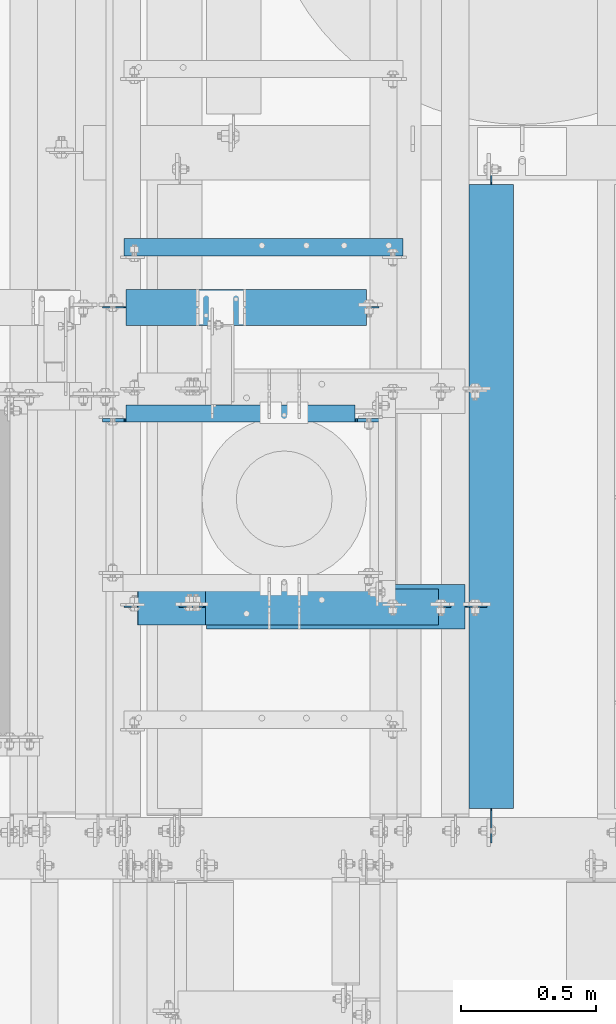
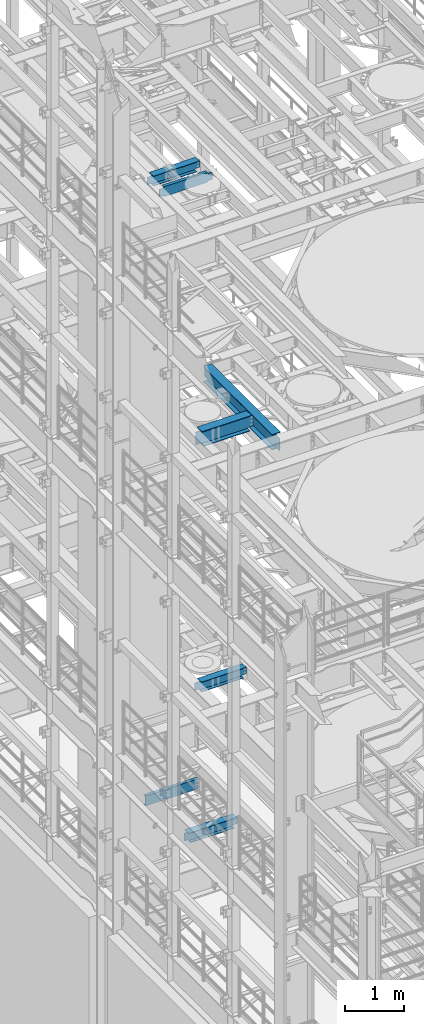
# One storey, part 1018 of 1876: 7 beams, 7 elements without a shape of their own.
"""IFC2X3 building model written with IfcOpenShell, lengths in millimetres."""

from ifc_helpers import new_model, si_unit, frame, origin_with_axes, place, context, subcontext, project, spatial, faceted_brep, material, type_object, element, aggregate, save


model = new_model("IFC2X3")

# Units and contexts
model_context = context("Model", 3, precision=1e-05, world=origin_with_axes())
body_context = subcontext(model_context, "Body", "Model", "MODEL_VIEW")
ifc_project = project(units=[si_unit("LENGTHUNIT", "METRE", prefix="MILLI"), si_unit("AREAUNIT", "SQUARE_METRE"), si_unit("VOLUMEUNIT", "CUBIC_METRE"), si_unit("MASSUNIT", "GRAM", prefix="KILO"), si_unit("TIMEUNIT", "SECOND"), si_unit("PLANEANGLEUNIT", "RADIAN"), si_unit("SOLIDANGLEUNIT", "STERADIAN"), si_unit("THERMODYNAMICTEMPERATUREUNIT", "DEGREE_CELSIUS"), si_unit("LUMINOUSINTENSITYUNIT", "LUMEN")], contexts=[model_context])

# Site, building, storey
site_placement = place(None, origin_with_axes())
site = spatial("IfcSite", under=ifc_project, at=site_placement, CompositionType="ELEMENT")
building_placement = place(site_placement, origin_with_axes())
building = spatial("IfcBuilding", under=site, at=building_placement, Name="Undefined", CompositionType="ELEMENT")
storey_placement = place(building_placement, origin_with_axes())
storey = spatial("IfcBuildingStorey", under=building, at=storey_placement, Name="Undefined", CompositionType="ELEMENT", Elevation=0.0)

# Assembly, beam
assembly_1_placement = place(storey_placement, origin_with_axes())
assembly_1 = element("IfcElementAssembly", 1, at=assembly_1_placement, inside=storey, Name="BEAM", AssemblyPlace="NOTDEFINED", PredefinedType="RIGID_FRAME")
ifc_material_1 = material(Name="STEEL/A992")
beam_type_1 = type_object("IfcBeamType", Name="W8X18", PredefinedType="NOTDEFINED")
beam_1_placement = place(assembly_1_placement, frame((1790.7, 3529.79856567383, 17880.0125), z_axis=(0.0, 0.0, 1.0), x_axis=(1.0, 0.0, 0.0)))
beam_1 = element("IfcBeam", 2, at=beam_1_placement, type_object=beam_type_1, material=ifc_material_1, Name="BEAM", ObjectType="W8X18", context=body_context, shape_type="Brep", body=[
    faceted_brep([(958.850000000001, -3.17500000000018, -95.25), (958.850000000001, -66.6750000000002, -95.25), (958.850000000001, -66.6750000000002, -103.1875), (958.850000000001, 66.6750000000002, -103.1875), (958.850000000001, 66.6750000000002, -95.25), (958.850000000001, 3.17500000000018, -95.25), (958.850000000001, 3.17500000000018, -90.48749980926), (958.850000000001, -3.17500000000018, -90.48749980926), (959.816729922588, 3.17500000000018, -85.6274202912136), (959.816729922588, -3.17500000000018, -85.6274202912136), (962.569743823067, 3.17500000000018, -81.50724382306), (962.569743823067, -3.17500000000018, -81.50724382306), (966.68992029122, 3.17500000000018, -78.7542299225825), (966.68992029122, -3.17500000000018, -78.7542299225825), (971.549999809266, 3.17500000000018, -77.7874999999949), (971.549999809266, -3.17500000000018, -77.7874999999949), (1050.925, -3.17500000000018, -77.7874999999949), (1050.925, 3.17500000000018, -77.7874999999949), (1003.3, -66.6750000000002, 103.1875), (1003.3, 66.6750000000002, 103.1875), (112.7125, 66.6750000000002, 103.1875), (112.7125, -66.6750000000002, 103.1875), (1003.61577334528, -66.6750000000002, 95.25), (1003.3, -66.6750000000002, 96.8374998092695), (112.7125, -66.6750000000002, 95.25), (1003.3, 66.6750000000002, 96.8374998092695), (1003.61577334528, 66.6750000000002, 95.25), (112.7125, 66.6750000000002, 95.25), (1003.61577334528, 3.17500000000018, 95.25), (112.7125, 3.17500000000018, 95.25), (112.7125, -66.6750000000002, -96.8374998092659), (112.7125, 66.6750000000002, -96.8374998092659), (112.7125, 66.6750000000002, -103.1875), (112.7125, -66.6750000000002, -103.1875), (112.396726654724, -66.6750000000002, -95.25), (112.396726654724, -3.17500000000018, -95.25), (111.745770077412, -3.17500000000018, -91.9774202912195), (111.745770077412, 3.17500002560791, -91.9774202912195), (112.396726654724, 3.17500009399191, -95.25), (112.396726654724, 66.6750000000002, -95.25), (108.992756176934, -3.17500000000018, -87.8572438230658), (108.992756176934, 3.17500002463203, -87.8572438230658), (104.87257970878, -3.17500000000018, -85.1042299225883), (104.87257970878, 3.17500002397719, -85.1042299225883), (100.012500190735, -3.17500000000018, -84.1375000000007), (100.012500190735, 3.17500002374254, -84.1375000000007), (23.8125, -3.17500000000018, -84.1375000000007), (23.8125, 3.17500000000018, -84.1375000000007), (23.8125, -3.17500000000018, 71.4375), (23.8125, 3.17500000000018, 71.4375), (100.012500190735, -3.17500000000018, 71.4375), (100.012500190735, 3.17499998808671, 71.4375), (104.87257970878, -3.17500000000018, 72.4042299225875), (104.87257970878, 3.17499998786207, 72.4042299225875), (108.992756176934, -3.17500000000018, 75.1572438230651), (108.992756176934, 3.17499998721996, 75.1572438230651), (111.745770077412, -3.17500000000018, 79.2774202912187), (111.745770077412, 3.17499998625954, 79.2774202912187), (112.7125, -3.17500000000018, 84.1374998092651), (112.7125, 3.17499998512631, 84.1374998092651), (112.7125, -3.17500000000018, 95.25), (1003.61577334528, -3.17500000000018, 95.25), (1004.26672992259, -3.17500000000018, 91.9774202912231), (1004.26672992259, 3.17500000000018, 91.9774202912231), (1007.01974382307, -3.17500000000018, 87.8572438230694), (1007.01974382307, 3.17500000000018, 87.8572438230694), (1011.13992029122, -3.17500000000018, 85.1042299225919), (1011.13992029122, 3.17500000000018, 85.1042299225919), (1015.99999980927, -3.17500000000018, 84.1375000000044), (1015.99999980927, 3.17500000000018, 84.1375000000044), (1050.925, -3.17500000000018, 84.1375000000044), (1050.925, 3.17500000000018, 84.1375000000044)], [[[0, 1, 2, 3, 4, 5, 6, 7]], [[7, 6, 8, 9]], [[9, 8, 10, 11]], [[11, 10, 12, 13]], [[13, 12, 14, 15]], [[16, 15, 14, 17]], [[18, 19, 20, 21]], [[22, 23, 18, 21, 24]], [[18, 23, 25, 19]], [[19, 25, 26, 27, 20]], [[26, 28, 29, 27]], [[30, 31, 32, 33]], [[34, 35, 36, 37, 38, 39, 31, 30]], [[40, 41, 37, 36]], [[42, 43, 41, 40]], [[44, 45, 43, 42]], [[46, 47, 45, 44]], [[48, 49, 47, 46]], [[50, 51, 49, 48]], [[52, 53, 51, 50]], [[54, 55, 53, 52]], [[56, 57, 55, 54]], [[58, 59, 57, 56]], [[21, 20, 27, 29, 59, 58, 60, 24]], [[61, 22, 24, 60]], [[62, 63, 28, 26, 25, 23, 22, 61]], [[64, 65, 63, 62]], [[66, 67, 65, 64]], [[68, 69, 67, 66]], [[70, 71, 69, 68]], [[71, 70, 16, 17]], [[41, 43, 45, 47, 49, 51, 53, 55, 57, 59, 29, 28, 63, 65, 67, 69, 71, 17, 14, 12, 10, 8, 6, 5, 38, 37]], [[5, 4, 39, 38]], [[4, 3, 32, 31, 39]], [[3, 2, 33, 32]], [[2, 1, 34, 30, 33]], [[1, 0, 35, 34]], [[0, 7, 9, 11, 13, 15, 16, 70, 68, 66, 64, 62, 61, 60, 58, 56, 54, 52, 50, 48, 46, 44, 42, 40, 36, 35]]]),
])
aggregate(assembly_1, [beam_1])

assembly_2_placement = place(storey_placement, origin_with_axes())
assembly_2 = element("IfcElementAssembly", 3, at=assembly_2_placement, inside=storey, Name="BEAM", AssemblyPlace="NOTDEFINED", PredefinedType="RIGID_FRAME")
beam_2_placement = place(assembly_2_placement, frame((2089.15, 2419.35, 8050.2125), z_axis=(0.0, 0.0, 1.0), x_axis=(1.0, 0.0, 0.0)))
beam_2 = element("IfcBeam", 4, at=beam_2_placement, type_object=beam_type_1, material=ifc_material_1, Name="BEAM", ObjectType="W8X18", context=body_context, shape_type="Brep", body=[
    faceted_brep([(10.3187500000004, -3.17500000000018, -77.7874999999995), (10.3187500000004, 3.17500000000018, -77.7874999999995), (96.043750190735, 3.17499999999927, -77.7875000000004), (96.043750190735, -3.17499999999927, -77.7875000000004), (100.903829708781, 3.17499999999927, -78.7542299225879), (100.903829708781, -3.17499999999927, -78.7542299225879), (105.024006176934, 3.17499999999927, -81.5072438230654), (105.024006176934, -3.17499999999927, -81.5072438230654), (107.777020077412, 3.17499999999927, -85.6274202912191), (107.777020077412, -3.17499999999927, -85.6274202912191), (108.74375, -3.17499999999927, -90.4874998092655), (108.74375, 3.17499999999927, -90.4874998092655), (108.74375, 3.17499999999927, -95.25), (108.74375, 66.6749999999993, -95.25), (108.74375, 66.6750000000002, -103.1875), (108.74375, -66.6750000000002, -103.1875), (108.74375, -66.6749999999993, -95.25), (108.74375, -3.17499999999927, -95.25), (971.550000000001, 66.6750000000002, 95.25), (971.550000000001, 3.17500000000018, 95.25), (108.743750000001, 3.17500000000018, 95.25), (108.743750000001, 66.6750000000002, 95.25), (96.0437501907354, -3.17500000000018, 77.7875000000004), (96.0437501907354, 3.17500000000018, 77.7875000000004), (10.3187500000004, 3.17500000000018, 77.7875000000004), (10.3187500000004, -3.17500000000018, 77.7875000000004), (100.903829708781, -3.17500000000018, 78.7542299225879), (100.903829708781, 3.17500000000018, 78.7542299225879), (105.024006176935, -3.17500000000018, 81.5072438230663), (105.024006176935, 3.17500000000018, 81.5072438230663), (107.777020077413, -3.17500000000018, 85.62742029122), (107.777020077413, 3.17500000000018, 85.62742029122), (108.743750000001, -3.17500000000018, 90.4874998092655), (108.743750000001, 3.17500000000018, 90.4874998092655), (971.550000000001, -66.6750000000002, 103.1875), (971.550000000001, 66.6750000000002, 103.1875), (108.743750000001, 66.6750000000002, 103.1875), (108.743750000001, -66.6750000000002, 103.1875), (971.550000000001, -66.6750000000002, 95.25), (108.743750000001, -66.6750000000002, 95.25), (971.550000000001, -3.17500000000018, 95.25), (108.743750000001, -3.17500000000018, 95.25), (971.550000000001, -3.17500000000018, 90.4874998092646), (971.550000000001, 3.17500000000018, 90.4874998092646), (972.516729922589, -3.17500000000018, 85.6274202912191), (972.516729922589, 3.17500000000018, 85.6274202912191), (975.269743823067, -3.17500000000018, 81.5072438230654), (975.269743823067, 3.17500000000018, 81.5072438230654), (979.389920291221, -3.17500000000018, 78.754229922587), (979.389920291221, 3.17500000000018, 78.754229922587), (984.249999809266, -3.17500000000018, 77.7874999999995), (984.249999809266, 3.17500000000018, 77.7874999999995), (1019.175, -3.17500000000018, 77.7874999999995), (1019.175, 3.17500000000018, 77.7874999999995), (1019.175, -3.17500000000018, -77.7875000000004), (1019.175, 3.17500000000018, -77.7875000000004), (936.624999809266, -3.17500000000018, -77.7875000000004), (936.624999809266, 3.17500000000018, -77.7875000000004), (931.764920291221, -3.17500000000018, -78.7542299225879), (931.764920291221, 3.17500000000018, -78.7542299225879), (927.644743823067, -3.17500000000018, -81.5072438230663), (927.644743823067, 3.17500000000018, -81.5072438230663), (924.891729922589, -3.17500000000018, -85.62742029122), (924.891729922589, 3.17500000000018, -85.62742029122), (923.925000000001, -3.17500000000018, -90.4874998092655), (923.925000000001, 3.17500000000018, -90.4874998092655), (923.925000000001, -3.17500000000018, -95.25), (923.925000000001, -66.6750000000002, -95.25), (923.925000000001, -66.6750000000002, -103.1875), (923.925000000001, 66.6750000000002, -103.1875), (923.925000000001, 66.6750000000002, -95.25), (923.925000000001, 3.17500000000018, -95.25)], [[[0, 1, 2, 3]], [[3, 2, 4, 5]], [[5, 4, 6, 7]], [[7, 6, 8, 9]], [[10, 11, 12, 13, 14, 15, 16, 17]], [[9, 8, 11, 10]], [[18, 19, 20, 21]], [[22, 23, 24, 25]], [[26, 27, 23, 22]], [[28, 29, 27, 26]], [[30, 31, 29, 28]], [[32, 33, 31, 30]], [[34, 35, 36, 37]], [[38, 34, 37, 39]], [[40, 38, 39, 41]], [[37, 36, 21, 20, 33, 32, 41, 39]], [[35, 18, 21, 36]], [[34, 38, 40, 42, 43, 19, 18, 35]], [[44, 45, 43, 42]], [[46, 47, 45, 44]], [[48, 49, 47, 46]], [[50, 51, 49, 48]], [[52, 53, 51, 50]], [[53, 52, 54, 55]], [[54, 56, 57, 55]], [[58, 59, 57, 56]], [[60, 61, 59, 58]], [[62, 63, 61, 60]], [[64, 65, 63, 62]], [[66, 67, 68, 69, 70, 71, 65, 64]], [[67, 66, 17, 16]], [[68, 67, 16, 15]], [[69, 68, 15, 14]], [[70, 69, 14, 13]], [[71, 70, 13, 12]], [[6, 4, 2, 1, 24, 23, 27, 29, 31, 33, 20, 19, 43, 45, 47, 49, 51, 53, 55, 57, 59, 61, 63, 65, 71, 12, 11, 8]], [[25, 24, 1, 0]], [[66, 64, 62, 60, 58, 56, 54, 52, 50, 48, 46, 44, 42, 40, 41, 32, 30, 28, 26, 22, 25, 0, 3, 5, 7, 9, 10, 17]]]),
])
aggregate(assembly_2, [beam_2])

assembly_3_placement = place(storey_placement, origin_with_axes())
assembly_3 = element("IfcElementAssembly", 5, at=assembly_3_placement, inside=storey, Name="BEAM", AssemblyPlace="NOTDEFINED", PredefinedType="RIGID_FRAME")
beam_3_placement = place(assembly_3_placement, frame((1930.4, 2419.35, 5027.6125), z_axis=(0.0, 0.0, 1.0), x_axis=(1.0, 0.0, 0.0)))
beam_3 = element("IfcBeam", 6, at=beam_3_placement, type_object=beam_type_1, material=ifc_material_1, Name="BEAM", ObjectType="W8X18", context=body_context, shape_type="Brep", body=[
    faceted_brep([(911.225000000001, -3.17500000000018, -95.25), (911.225000000001, -66.6750000000002, -95.25), (911.225000000001, -66.6750000000002, -103.1875), (911.225000000001, 66.6750000000002, -103.1875), (911.225000000001, 66.6750000000002, -95.25), (911.225000000001, 3.17500000000018, -95.25), (911.225000000001, 3.17500000000018, -90.4874998092664), (911.225000000001, -3.17500000000018, -90.4874998092664), (912.191729922589, 3.17500000000018, -85.6274202912209), (912.191729922589, -3.17500000000018, -85.6274202912209), (914.944743823067, 3.17500000000018, -81.5072438230673), (914.944743823067, -3.17500000000018, -81.5072438230673), (919.06492029122, 3.17500000000018, -78.7542299225888), (919.06492029122, -3.17500000000018, -78.7542299225888), (923.924999809266, 3.17500000000018, -77.7875000000013), (923.924999809266, -3.17500000000018, -77.7875000000013), (1000.125, -3.17500000000018, -77.7875000000013), (1000.125, 3.17500000000018, -77.7875000000013), (15.8750000000005, 66.6750000000002, 103.1875), (15.8750000000005, -66.6750000000002, 103.1875), (949.325000000001, -66.6750000000002, 103.1875), (949.325000000001, 66.6750000000002, 103.1875), (15.8750000000005, 66.6750000000002, 96.837499809264), (15.8750000000005, -66.6750000000002, 96.837499809264), (15.5592266547251, -66.6750000000002, 95.25), (949.640773345276, -66.6750000000002, 95.25), (949.325000000001, -66.6750000000002, 96.837499809264), (949.325000000001, 66.6750000000002, 96.837499809264), (15.5592266547251, 66.6750000000002, 95.25), (949.640773345276, 66.6750000000002, 95.25), (15.5592266547251, 3.17500000000018, 95.25), (949.640773345276, 3.17500000000018, 95.25), (53.9750000000006, -3.17500000000018, -90.4874998092664), (53.9750000000006, 3.17500000000018, -90.4874998092664), (53.9750000000004, 3.17500000000018, -95.25), (53.9750000000004, 66.6750000000002, -95.25), (53.9750000000004, 66.6750000000002, -103.1875), (53.9750000000004, -66.6750000000002, -103.1875), (53.9750000000004, -66.6750000000002, -95.25), (53.9750000000004, -3.17500000000018, -95.25), (53.0082700774128, -3.17500000000018, -85.6274202912209), (53.0082700774128, 3.17500000000018, -85.6274202912209), (50.2552561769346, -3.17500000000018, -81.5072438230673), (50.2552561769346, 3.17500000000018, -81.5072438230673), (46.1350797087809, -3.17500000000018, -78.7542299225888), (46.1350797087809, 3.17500000000018, -78.7542299225888), (41.2750001907355, -3.17500000000018, -77.7875000000013), (41.2750001907355, 3.17500000000018, -77.7875000000013), (-34.9249999999993, -3.17500000000018, -77.7875000000013), (-34.9249999999993, 3.17500000000018, -77.7875000000013), (-34.9249999999993, -3.17500000000018, 84.1374999999989), (-34.9249999999993, 3.17500000000018, 84.1374999999989), (3.17500019073532, -3.17500000000018, 84.1374999999989), (3.17500019073532, 3.17500000000018, 84.1374999999989), (8.03507970878081, -3.17500000000018, 85.1042299225865), (8.03507970878081, 3.17500000000018, 85.1042299225865), (12.1552561769345, -3.17500000000018, 87.8572438230649), (12.1552561769345, 3.17500000000018, 87.8572438230649), (14.9082700774127, -3.17500000000018, 91.9774202912186), (14.9082700774127, 3.17500000000018, 91.9774202912186), (15.5592266547251, -3.17500000000018, 95.25), (949.640773345276, -3.17500000000018, 95.25), (950.291729922588, -3.17500000000018, 91.9774202912186), (950.291729922588, 3.17500000000018, 91.9774202912186), (953.044743823067, -3.17500000000018, 87.8572438230649), (953.044743823067, 3.17500000000018, 87.8572438230649), (957.16492029122, -3.17500000000018, 85.1042299225865), (957.16492029122, 3.17500000000018, 85.1042299225865), (962.024999809266, -3.17500000000018, 84.1374999999989), (962.024999809266, 3.17500000000018, 84.1374999999989), (1000.125, -3.17500000000018, 84.1374999999989), (1000.125, 3.17500000000018, 84.1374999999989)], [[[0, 1, 2, 3, 4, 5, 6, 7]], [[7, 6, 8, 9]], [[9, 8, 10, 11]], [[11, 10, 12, 13]], [[13, 12, 14, 15]], [[16, 15, 14, 17]], [[18, 19, 20, 21]], [[19, 18, 22, 23]], [[20, 19, 23, 24, 25, 26]], [[20, 26, 27, 21]], [[28, 22, 18, 21, 27, 29]], [[30, 28, 29, 31]], [[32, 33, 34, 35, 36, 37, 38, 39]], [[40, 41, 33, 32]], [[42, 43, 41, 40]], [[44, 45, 43, 42]], [[46, 47, 45, 44]], [[48, 49, 47, 46]], [[50, 51, 49, 48]], [[52, 53, 51, 50]], [[54, 55, 53, 52]], [[56, 57, 55, 54]], [[58, 59, 57, 56]], [[23, 22, 28, 30, 59, 58, 60, 24]], [[24, 60, 61, 25]], [[62, 63, 31, 29, 27, 26, 25, 61]], [[64, 65, 63, 62]], [[66, 67, 65, 64]], [[68, 69, 67, 66]], [[70, 71, 69, 68]], [[71, 70, 16, 17]], [[12, 10, 8, 6, 5, 34, 33, 41, 43, 45, 47, 49, 51, 53, 55, 57, 59, 30, 31, 63, 65, 67, 69, 71, 17, 14]], [[35, 34, 5, 4]], [[36, 35, 4, 3]], [[37, 36, 3, 2]], [[38, 37, 2, 1]], [[39, 38, 1, 0]], [[70, 68, 66, 64, 62, 61, 60, 58, 56, 54, 52, 50, 48, 46, 44, 42, 40, 32, 39, 0, 7, 9, 11, 13, 15, 16]]]),
])
aggregate(assembly_3, [beam_3])

assembly_4_placement = place(storey_placement, origin_with_axes())
assembly_4 = element("IfcElementAssembly", 7, at=assembly_4_placement, inside=storey, Name="BEAM", AssemblyPlace="NOTDEFINED", PredefinedType="RIGID_FRAME")
ifc_material_2 = material(Name="STEEL/A36")
beam_type_2 = type_object("IfcBeamType", Name="C8X18.75", PredefinedType="NOTDEFINED")
beam_4_placement = place(assembly_4_placement, frame((1880.15454293187, 3752.84959106446, 4981.575), z_axis=(0.0, 0.0, -1.0), x_axis=(1.0, 0.0, 0.0)))
beam_4 = element("IfcBeam", 8, at=beam_4_placement, type_object=beam_type_2, material=ifc_material_2, Name="BEAM", ObjectType="C8X18.75", context=body_context, shape_type="Brep", body=[
    faceted_brep([(15.3204570681301, 31.75, -101.6), (15.3204570681301, 31.75, 101.6), (1050.37045706813, 31.75, 101.6), (1050.37045706813, 31.75, -101.6), (15.3204570681301, -31.75, 101.6), (1050.37045706813, -31.75, 101.6), (15.3204570681301, -31.75, 97.3645500000002), (1050.37045706813, -31.75, 97.3645500000002), (15.3204570681301, 19.05, 88.9012700000003), (1050.37045706813, 19.05, 88.9012700000003), (15.3204570681301, 19.05, -88.9012700000003), (1050.37045706813, 19.05, -88.9012700000003), (15.3204570681301, -31.75, -97.3645500000002), (1050.37045706813, -31.75, -97.3645500000002), (15.3204570681301, -31.75, -101.6), (1050.37045706813, -31.75, -101.6)], [[[0, 1, 2, 3]], [[1, 4, 5, 2]], [[4, 6, 7, 5]], [[6, 8, 9, 7]], [[8, 10, 11, 9]], [[10, 12, 13, 11]], [[12, 14, 15, 13]], [[14, 0, 3, 15]], [[5, 7, 9, 11, 13, 15, 3, 2]], [[14, 12, 10, 8, 6, 4, 1, 0]]]),
])
aggregate(assembly_4, [beam_4])

assembly_5_placement = place(storey_placement, origin_with_axes())
assembly_5 = element("IfcElementAssembly", 9, at=assembly_5_placement, inside=storey, Name="BEAM", AssemblyPlace="NOTDEFINED", PredefinedType="RIGID_FRAME")
beam_5_placement = place(assembly_5_placement, frame((1790.7, 3136.9, 17881.6), z_axis=(0.0, 0.0, -1.0), x_axis=(1.0, 0.0, 0.0)))
beam_5 = element("IfcBeam", 10, at=beam_5_placement, type_object=beam_type_2, material=ifc_material_2, Name="BEAM", ObjectType="C8X18.75", context=body_context, shape_type="Brep", body=[
    faceted_brep([(962.025000000005, -31.75, -97.3645499999984), (962.025000000005, -31.75, -101.599999999999), (962.025000000005, 31.75, -101.599999999999), (962.025000000005, 31.75, -88.8999998092659), (962.024999998448, 19.0499532632716, -88.901149643516), (962.991729922593, 31.75, -84.0399202912195), (962.991729922593, 19.0498228018992, -84.0399202912195), (965.744743823071, 31.75, -79.9197438230658), (965.744743823071, 19.0498284685614, -79.9197438230658), (969.864920291225, 31.75, -77.1667299225883), (969.864920291225, 19.0498322976568, -77.1667299225883), (974.72499980927, 31.75, -76.2000000000007), (974.72499980927, 19.0498337062413, -76.2000000000007), (1050.925, 19.0500000000002, -76.2000000000007), (1050.925, 31.75, -76.2000000000007), (112.712500000005, -31.75, 101.599999999999), (112.712500000005, -31.75, 97.3645499999984), (962.025000000005, -31.75, 97.3645499999984), (962.025000000005, -31.75, 101.599999999999), (112.712500000005, 31.75, 101.599999999999), (962.025000000005, 31.75, 101.599999999999), (112.712500000005, 19.0495067605989, -88.8999998092659), (112.712500000005, 31.75, -88.8999998092659), (112.712500000005, 31.75, -101.599999999999), (112.712500000005, -31.75, -101.599999999999), (112.712500000005, -31.75, -97.3645499999984), (111.745770077417, 19.0497988594598, -84.0399202912195), (111.745770077417, 31.75, -84.0399202912195), (108.992756176939, 19.0498047194646, -79.9197438230658), (108.992756176939, 31.75, -79.9197438230658), (104.872579708785, 19.0498086389457, -77.1667299225883), (104.872579708785, 31.75, -77.1667299225883), (100.01250019074, 19.0498100211971, -76.2000000000007), (100.01250019074, 31.75, -76.2000000000007), (23.8125000000045, 19.0500000000002, -76.2000000000007), (23.8125000000045, 31.75, -76.2000000000007), (23.8125000000041, 19.0500000000002, 76.2000000000007), (23.8125000000041, 31.75, 76.2000000000007), (100.01250019074, 19.0500238039972, 76.2000000000007), (100.01250019074, 31.75, 76.2000000000007), (104.872579708785, 19.0500251630438, 77.1667299225883), (104.872579708785, 31.75, 77.1667299225883), (108.992756176939, 19.0500290332807, 79.9197438230658), (108.992756176939, 31.75, 79.9197438230658), (111.745770077417, 19.0500348254996, 84.0399202912195), (111.745770077417, 31.75, 84.0399202912195), (112.712500000005, 19.0500000000002, 88.9012699999985), (112.712500000005, 31.75, 88.8999998092659), (962.025000000005, 19.0500000000002, 88.9012699999985), (962.025000000005, 31.75, 88.8999998092659), (962.991729922593, 19.0500483399915, 84.0399202912195), (962.991729922593, 31.75, 84.0399202912195), (965.744743823071, 19.0500428478385, 79.9197438230658), (965.744743823071, 31.75, 79.9197438230658), (969.864920291225, 19.0500392148351, 77.1667299225883), (969.864920291225, 31.75, 77.1667299225883), (974.72499980927, 19.0500379940727, 76.2000000000007), (974.72499980927, 31.75, 76.2000000000007), (1050.925, 19.0500000000002, 76.2000000000007), (1050.925, 31.75, 76.2000000000007)], [[[0, 1, 2, 3, 4]], [[4, 3, 5, 6]], [[6, 5, 7, 8]], [[8, 7, 9, 10]], [[10, 9, 11, 12]], [[13, 12, 11, 14]], [[15, 16, 17, 18]], [[19, 15, 18, 20]], [[21, 22, 23, 24, 25]], [[26, 27, 22, 21]], [[28, 29, 27, 26]], [[30, 31, 29, 28]], [[32, 33, 31, 30]], [[34, 35, 33, 32]], [[36, 37, 35, 34]], [[38, 39, 37, 36]], [[40, 41, 39, 38]], [[42, 43, 41, 40]], [[44, 45, 43, 42]], [[46, 47, 45, 44]], [[15, 19, 47, 46, 16]], [[16, 46, 48, 17]], [[18, 17, 48, 49, 20]], [[50, 51, 49, 48]], [[52, 53, 51, 50]], [[54, 55, 53, 52]], [[56, 57, 55, 54]], [[58, 59, 57, 56]], [[59, 58, 13, 14]], [[9, 7, 5, 3, 2, 23, 22, 27, 29, 31, 33, 35, 37, 39, 41, 43, 45, 47, 19, 20, 49, 51, 53, 55, 57, 59, 14, 11]], [[24, 23, 2, 1]], [[25, 24, 1, 0]], [[21, 25, 0, 4]], [[58, 56, 54, 52, 50, 48, 46, 44, 42, 40, 38, 36, 34, 32, 30, 28, 26, 21, 4, 6, 8, 10, 12, 13]]]),
])
aggregate(assembly_5, [beam_5])

assembly_6_placement = place(storey_placement, origin_with_axes())
assembly_6 = element("IfcElementAssembly", 11, at=assembly_6_placement, inside=storey, Name="BEAM", AssemblyPlace="NOTDEFINED", PredefinedType="RIGID_FRAME")
beam_type_3 = type_object("IfcBeamType", Name="W12X30", PredefinedType="NOTDEFINED")
beam_6_placement = place(assembly_6_placement, frame((2101.85, 2419.35, 13152.4375), z_axis=(0.0, 0.0, 1.0), x_axis=(1.0, 0.0, 0.0)))
beam_6 = element("IfcBeam", 12, at=beam_6_placement, type_object=beam_type_3, material=ifc_material_1, Name="BEAM", ObjectType="W12X30", context=body_context, shape_type="Brep", body=[
    faceted_brep([(1025.525, -3.17500000000018, -146.049999999999), (1025.525, -82.5500000000002, -146.049999999999), (1025.525, -82.5500000000002, -157.1625), (1025.525, 82.5500000000002, -157.1625), (1025.525, 82.5500000000002, -146.049999999999), (1025.525, 3.17500000000018, -146.049999999999), (1025.525, 3.17500000000018, -144.462499809264), (1025.525, -3.17500000000018, -144.462499809264), (1026.49172992259, 3.17500000000018, -139.602420291218), (1026.49172992259, -3.17500000000018, -139.602420291218), (1029.24474382307, 3.17500000000018, -135.482243823064), (1029.24474382307, -3.17500000000018, -135.482243823064), (1033.36492029122, 3.17500000000018, -132.729229922586), (1033.36492029122, -3.17500000000018, -132.729229922586), (1038.22499980927, 3.17500000000018, -131.762499999999), (1038.22499980927, -3.17500000000018, -131.762499999999), (1139.825, -3.17500000000018, -131.762499999999), (1139.825, 3.17500000000018, -131.762499999999), (98.4250000000029, 3.17500000000018, 146.049999999999), (98.4250000000002, 82.5500000000002, 146.049999999999), (1057.275, 82.5500000000002, 146.049999999999), (1057.275, 3.17500000000018, 146.049999999999), (130.175000000001, -3.17500000000018, -144.462499809264), (130.175000000001, 3.17500000000018, -144.462499809264), (130.175000000001, 3.17500000000018, -146.049999999999), (130.175000000001, 82.5500000000002, -146.049999999999), (130.175000000001, 82.5500000000002, -157.1625), (130.175000000001, -82.5500000000002, -157.1625), (130.175000000001, -82.5500000000002, -146.049999999999), (130.175000000001, -3.17500000000018, -146.049999999999), (129.208270077413, -3.17500000000018, -139.602420291218), (129.208270077413, 3.17500000000018, -139.602420291218), (126.455256176935, -3.17500000000018, -135.482243823064), (126.455256176935, 3.17500000000018, -135.482243823064), (122.335079708781, -3.17500000000018, -132.729229922586), (122.335079708781, 3.17500000000018, -132.729229922586), (117.475000190736, -3.17500000000018, -131.762499999999), (117.475000190736, 3.17500000000018, -131.762499999999), (15.875, -3.17500000000018, -131.762499999999), (15.875, 3.17500000000018, -131.762499999999), (15.875, -3.17500000000018, 125.4125), (15.875, 3.17500000000018, 125.4125), (85.725000190736, -3.17500000000018, 125.4125), (85.725000190736, 3.17500000000018, 125.4125), (90.5850797087814, -3.17500000000018, 126.379229922588), (90.5850797087814, 3.17500000000018, 126.379229922588), (94.7052561769351, -3.17500000000018, 129.132243823065), (94.7052561769351, 3.17500000000018, 129.132243823065), (97.4582700774131, -3.17500000000018, 133.252420291219), (97.4582700774131, 3.17500000000018, 133.252420291219), (98.4250000000011, -3.17500000000018, 138.112499809266), (98.4250000000011, 3.17500000000018, 138.112499809266), (98.4250000000011, -82.5500000000002, 157.1625), (98.4250000000011, 82.5500000000002, 157.1625), (98.4250000000029, -3.17500000000018, 146.049999999999), (98.4250000000002, -82.5500000000002, 146.049999999999), (1057.275, -3.17500000000018, 146.049999999999), (1057.275, -82.5500000000002, 146.049999999999), (1057.275, -82.5500000000002, 157.1625), (1057.275, 82.5500000000002, 157.1625), (1057.275, -3.17500000000018, 138.112499809266), (1057.275, 3.17500000000018, 138.112499809266), (1058.24172992259, -3.17500000000018, 133.252420291219), (1058.24172992259, 3.17500000000018, 133.252420291219), (1060.99474382307, -3.17500000000018, 129.132243823065), (1060.99474382307, 3.17500000000018, 129.132243823065), (1065.11492029122, -3.17500000000018, 126.379229922588), (1065.11492029122, 3.17500000000018, 126.379229922588), (1069.97499980927, -3.17500000000018, 125.4125), (1069.97499980927, 3.17500000000018, 125.4125), (1139.825, -3.17500000000018, 125.4125), (1139.825, 3.17500000000018, 125.4125)], [[[0, 1, 2, 3, 4, 5, 6, 7]], [[7, 6, 8, 9]], [[9, 8, 10, 11]], [[11, 10, 12, 13]], [[13, 12, 14, 15]], [[16, 15, 14, 17]], [[18, 19, 20, 21]], [[22, 23, 24, 25, 26, 27, 28, 29]], [[30, 31, 23, 22]], [[32, 33, 31, 30]], [[34, 35, 33, 32]], [[36, 37, 35, 34]], [[38, 39, 37, 36]], [[40, 41, 39, 38]], [[42, 43, 41, 40]], [[44, 45, 43, 42]], [[46, 47, 45, 44]], [[48, 49, 47, 46]], [[50, 51, 49, 48]], [[52, 53, 19, 18, 51, 50, 54, 55]], [[55, 54, 56, 57]], [[52, 55, 57, 58]], [[53, 52, 58, 59]], [[19, 53, 59, 20]], [[58, 57, 56, 60, 61, 21, 20, 59]], [[62, 63, 61, 60]], [[64, 65, 63, 62]], [[66, 67, 65, 64]], [[68, 69, 67, 66]], [[70, 71, 69, 68]], [[71, 70, 16, 17]], [[12, 10, 8, 6, 5, 24, 23, 31, 33, 35, 37, 39, 41, 43, 45, 47, 49, 51, 18, 21, 61, 63, 65, 67, 69, 71, 17, 14]], [[25, 24, 5, 4]], [[26, 25, 4, 3]], [[27, 26, 3, 2]], [[28, 27, 2, 1]], [[29, 28, 1, 0]], [[70, 68, 66, 64, 62, 60, 56, 54, 50, 48, 46, 44, 42, 40, 38, 36, 34, 32, 30, 22, 29, 0, 7, 9, 11, 13, 15, 16]]]),
])
aggregate(assembly_6, [beam_6])

assembly_7_placement = place(storey_placement, origin_with_axes())
assembly_7 = element("IfcElementAssembly", 13, at=assembly_7_placement, inside=storey, Name="BEAM", AssemblyPlace="NOTDEFINED", PredefinedType="RIGID_FRAME")
beam_7_placement = place(assembly_7_placement, frame((3257.55, 1524.0, 13152.4375), z_axis=(0.0, 0.0, 1.0), x_axis=(0.0, 1.0, 0.0)))
beam_7 = element("IfcBeam", 14, at=beam_7_placement, type_object=beam_type_3, material=ifc_material_1, Name="BEAM", ObjectType="W12X30", context=body_context, shape_type="Brep", body=[
    faceted_brep([(19.8437500000002, -3.17500000000018, -131.762499999993), (19.8437500000002, 3.17500000000018, -131.762499999993), (134.143750190735, 3.17500000000018, -131.762500000001), (134.143750190735, -3.17500000000018, -131.762500000001), (139.00382970878, 3.17500000000018, -132.729229922588), (139.00382970878, -3.17500000000018, -132.729229922588), (143.124006176934, 3.17500000000018, -135.482243823066), (143.124006176934, -3.17500000000018, -135.482243823066), (145.877020077412, 3.17500000000018, -139.602420291219), (145.877020077412, -3.17500000000018, -139.602420291219), (146.84375, -3.17500000000018, -144.462499809266), (146.84375, 3.17500000000018, -144.462499809266), (146.84375, 3.17500000000018, -146.049999999999), (146.84375, 82.5500000000002, -146.049999999999), (146.84375, 82.5500000000002, -157.1625), (146.84375, -82.5500000000002, -157.1625), (146.84375, -82.5500000000002, -146.049999999999), (146.84375, -3.17500000000018, -146.049999999999), (2461.41875, 82.5500000000002, 146.049999999999), (2461.41875, 3.17500000000018, 146.049999999999), (146.84375, 3.17500000000018, 146.049999999999), (146.84375, 82.5500000000002, 146.049999999999), (134.143750190735, -3.17500000000018, 119.0625), (134.143750190735, 3.17500000000018, 119.0625), (19.8437491105051, 3.17499999999995, 119.062500000004), (19.8437491105051, -3.17499999999995, 119.062500000004), (139.00382970878, -3.17500000000018, 120.029229922588), (139.00382970878, 3.17500000000018, 120.029229922588), (143.124006176934, -3.17500000000018, 122.782243823065), (143.124006176934, 3.17500000000018, 122.782243823065), (145.877020077412, -3.17500000000018, 126.902420291219), (145.877020077412, 3.17500000000018, 126.902420291219), (146.84375, -3.17500000000018, 131.762499809265), (146.84375, 3.17500000000018, 131.762499809265), (2461.41875, -82.5500000000002, 157.1625), (2461.41875, 82.5500000000002, 157.1625), (146.84375, 82.5500000000002, 157.1625), (146.84375, -82.5500000000002, 157.1625), (2461.41875, -82.5500000000002, 146.049999999999), (146.84375, -82.5500000000002, 146.049999999999), (2461.41875, -3.17500000000018, 146.049999999999), (146.84375, -3.17500000000018, 146.049999999999), (2461.41875, -3.17500000000018, 131.762499809265), (2461.41875, 3.17500000000018, 131.762499809265), (2462.38547992259, -3.17500000000018, 126.902420291219), (2462.38547992259, 3.17500000000018, 126.902420291219), (2465.13849382307, -3.17500000000018, 122.782243823065), (2465.13849382307, 3.17500000000018, 122.782243823065), (2469.25867029122, -3.17500000000018, 120.029229922588), (2469.25867029122, 3.17500000000018, 120.029229922588), (2474.11874980927, -3.17500000000018, 119.0625), (2474.11874980927, 3.17500000000018, 119.0625), (2563.01875, -3.17500000000018, 119.0625), (2563.01875, 3.17500000000018, 119.0625), (2563.01875, -3.17500000000018, -131.762500000001), (2563.01875, 3.17500000000018, -131.762500000001), (2474.11874980927, -3.17500000000018, -131.762500000001), (2474.11874980927, 3.17500000000018, -131.762500000001), (2469.25867029122, -3.17500000000018, -132.729229922588), (2469.25867029122, 3.17500000000018, -132.729229922588), (2465.13849382307, -3.17500000000018, -135.482243823066), (2465.13849382307, 3.17500000000018, -135.482243823066), (2462.38547992259, -3.17500000000018, -139.602420291219), (2462.38547992259, 3.17500000000018, -139.602420291219), (2461.41875, -3.17500000000018, -144.462499809266), (2461.41875, 3.17500000000018, -144.462499809266), (2461.41875, -3.17500000000018, -146.049999999999), (2461.41875, -82.5500000000002, -146.049999999999), (2461.41875, -82.5500000000002, -157.1625), (2461.41875, 82.5500000000002, -157.1625), (2461.41875, 82.5500000000002, -146.049999999999), (2461.41875, 3.17500000000018, -146.049999999999)], [[[0, 1, 2, 3]], [[3, 2, 4, 5]], [[5, 4, 6, 7]], [[7, 6, 8, 9]], [[10, 11, 12, 13, 14, 15, 16, 17]], [[9, 8, 11, 10]], [[18, 19, 20, 21]], [[22, 23, 24, 25]], [[26, 27, 23, 22]], [[28, 29, 27, 26]], [[30, 31, 29, 28]], [[32, 33, 31, 30]], [[34, 35, 36, 37]], [[38, 34, 37, 39]], [[40, 38, 39, 41]], [[37, 36, 21, 20, 33, 32, 41, 39]], [[35, 18, 21, 36]], [[34, 38, 40, 42, 43, 19, 18, 35]], [[44, 45, 43, 42]], [[46, 47, 45, 44]], [[48, 49, 47, 46]], [[50, 51, 49, 48]], [[52, 53, 51, 50]], [[53, 52, 54, 55]], [[54, 56, 57, 55]], [[58, 59, 57, 56]], [[60, 61, 59, 58]], [[62, 63, 61, 60]], [[64, 65, 63, 62]], [[66, 67, 68, 69, 70, 71, 65, 64]], [[67, 66, 17, 16]], [[68, 67, 16, 15]], [[69, 68, 15, 14]], [[70, 69, 14, 13]], [[71, 70, 13, 12]], [[6, 4, 2, 1, 24, 23, 27, 29, 31, 33, 20, 19, 43, 45, 47, 49, 51, 53, 55, 57, 59, 61, 63, 65, 71, 12, 11, 8]], [[25, 24, 1, 0]], [[66, 64, 62, 60, 58, 56, 54, 52, 50, 48, 46, 44, 42, 40, 41, 32, 30, 28, 26, 22, 25, 0, 3, 5, 7, 9, 10, 17]]]),
])
aggregate(assembly_7, [beam_7])

save(model, "model.ifc")
